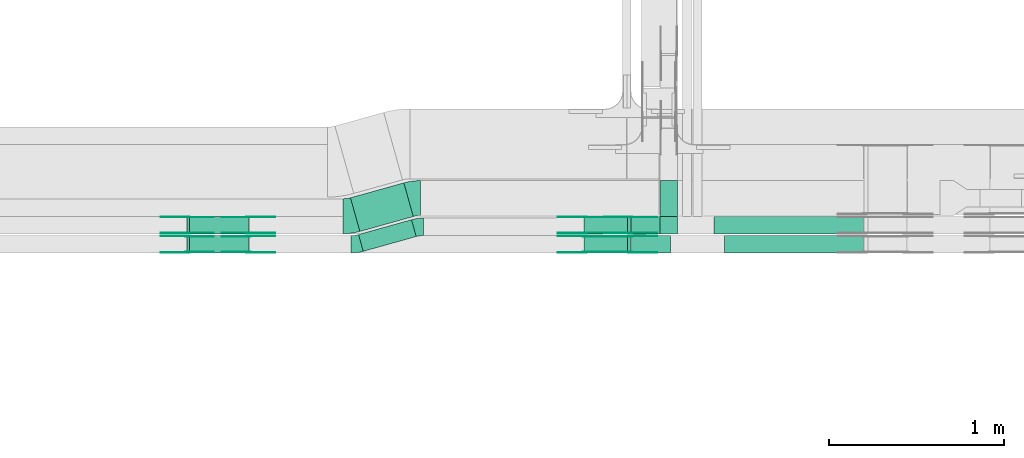
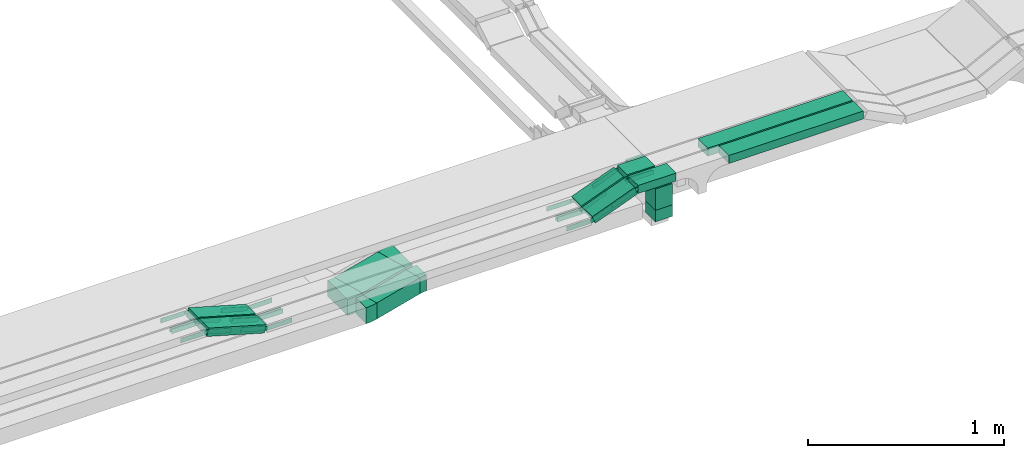
# One storey, part 21 of 27: 37 flow fittings, 11 flow segments.
"""IFC2X3 building model written with IfcOpenShell, lengths in millimetres."""

from ifc_helpers import new_model, entity, si_unit, converted_unit, derived_unit, direction, frame, frame_2d, origin, origin_2d_with_axis, place, context, subcontext, project, spatial, polyline, circle_curve, parameter, trimmed, segment, composite_curve, rectangle, outline, extrude, source, transform, mapped, material, material_list, type_object, type_shapes, element, save


model = new_model("IFC2X3")

# Units and contexts
model_context = context("Model", 3, precision=0.01, world=origin(), true_north=direction((6.12303176911189e-17, 1.0)))
body_context = subcontext(model_context, "Body", "Model", "MODEL_VIEW")
ifc_project = project(units=[si_unit("LENGTHUNIT", "METRE", prefix="MILLI"), si_unit("AREAUNIT", "SQUARE_METRE"), si_unit("VOLUMEUNIT", "CUBIC_METRE"), converted_unit("PLANEANGLEUNIT", "DEGREE", entity("IfcRatioMeasure", 0.0174532925199433), si_unit("PLANEANGLEUNIT", "RADIAN"), dimensions=[0, 0, 0, 0, 0, 0, 0]), si_unit("MASSUNIT", "GRAM", prefix="KILO"), derived_unit("MASSDENSITYUNIT", [(si_unit("MASSUNIT", "GRAM", prefix="KILO"), 1), (si_unit("LENGTHUNIT", "METRE"), -3)]), derived_unit("MOMENTOFINERTIAUNIT", [(si_unit("LENGTHUNIT", "METRE"), 4)]), si_unit("TIMEUNIT", "SECOND"), si_unit("FREQUENCYUNIT", "HERTZ"), si_unit("THERMODYNAMICTEMPERATUREUNIT", "DEGREE_CELSIUS"), derived_unit("THERMALTRANSMITTANCEUNIT", [(si_unit("MASSUNIT", "GRAM", prefix="KILO"), 1), (si_unit("THERMODYNAMICTEMPERATUREUNIT", "KELVIN"), -1), (si_unit("TIMEUNIT", "SECOND"), -3)]), derived_unit("VOLUMETRICFLOWRATEUNIT", [(si_unit("LENGTHUNIT", "METRE"), 3), (si_unit("TIMEUNIT", "SECOND"), -1)]), derived_unit("MASSFLOWRATEUNIT", [(si_unit("MASSUNIT", "GRAM", prefix="KILO"), 1), (si_unit("TIMEUNIT", "SECOND"), -1)]), derived_unit("ROTATIONALFREQUENCYUNIT", [(si_unit("TIMEUNIT", "SECOND"), -1)]), si_unit("ELECTRICCURRENTUNIT", "AMPERE"), si_unit("ELECTRICVOLTAGEUNIT", "VOLT"), si_unit("POWERUNIT", "WATT"), si_unit("FORCEUNIT", "NEWTON", prefix="KILO"), si_unit("ILLUMINANCEUNIT", "LUX"), si_unit("LUMINOUSFLUXUNIT", "LUMEN"), si_unit("LUMINOUSINTENSITYUNIT", "CANDELA"), derived_unit("USERDEFINED", [(si_unit("MASSUNIT", "GRAM", prefix="KILO"), -1), (si_unit("LENGTHUNIT", "METRE"), -2), (si_unit("TIMEUNIT", "SECOND"), 3), (si_unit("LUMINOUSFLUXUNIT", "LUMEN"), 1)]), derived_unit("LINEARVELOCITYUNIT", [(si_unit("LENGTHUNIT", "METRE"), 1), (si_unit("TIMEUNIT", "SECOND"), -1)]), si_unit("PRESSUREUNIT", "PASCAL"), derived_unit("USERDEFINED", [(si_unit("LENGTHUNIT", "METRE"), -2), (si_unit("MASSUNIT", "GRAM", prefix="KILO"), 1), (si_unit("TIMEUNIT", "SECOND"), -2)]), derived_unit("LINEARFORCEUNIT", [(si_unit("MASSUNIT", "GRAM", prefix="KILO"), 1), (si_unit("LENGTHUNIT", "METRE"), 1), (si_unit("TIMEUNIT", "SECOND"), -2), (si_unit("LENGTHUNIT", "METRE"), -1)]), derived_unit("PLANARFORCEUNIT", [(si_unit("MASSUNIT", "GRAM", prefix="KILO"), 1), (si_unit("LENGTHUNIT", "METRE"), 1), (si_unit("TIMEUNIT", "SECOND"), -2), (si_unit("LENGTHUNIT", "METRE"), -2)])], contexts=[model_context])

# Site, building, storey
site_placement = place(None, origin())
site = spatial("IfcSite", under=ifc_project, at=site_placement, CompositionType="ELEMENT")
building_placement = place(site_placement, origin())
building = spatial("IfcBuilding", under=site, at=building_placement, CompositionType="ELEMENT")
storey_placement = place(building_placement, origin())
storey = spatial("IfcBuildingStorey", under=building, at=storey_placement, CompositionType="ELEMENT", Elevation=0.0)

# Flow segments
cable_carrier_segment_type = type_object("IfcCableCarrierSegmentType", PredefinedType="CABLETRAYSEGMENT")
flow_segment_1_placement = place(storey_placement, frame((62283.44, 8309.65, 2600.0)))
element("IfcFlowSegment", 1, at=flow_segment_1_placement, inside=storey, type_object=cable_carrier_segment_type, context=body_context, shape_type="SweptSolid", body=[
    extrude(rectangle(XDim=314.534339130373, YDim=99.9999999999995, at=origin_2d_with_axis()), frame((164.92, 90.44, 0.0), z_axis=(0.0, 0.0, 1.0), x_axis=(0.963181508900073, 0.268851968400788, 0.0)), (0.0, 0.0, 1.0), 100.0),
])
flow_segment_2_placement = place(storey_placement, frame((62237.29, 8423.33, 2600.0)))
element("IfcFlowSegment", 2, at=flow_segment_2_placement, inside=storey, type_object=cable_carrier_segment_type, context=body_context, shape_type="SweptSolid", body=[
    extrude(rectangle(XDim=316.935834936436, YDim=199.999999999999, at=origin_2d_with_axis()), frame((179.52, 138.92, 0.0), z_axis=(0.0, 0.0, 1.0), x_axis=(0.963181508900077, 0.268851968400775, 0.0)), (0.0, 0.0, 1.0), 99.9999999999999),
])
flow_segment_3_placement = place(storey_placement, frame((64007.77, 8409.33, 2550.0)))
element("IfcFlowSegment", 3, at=flow_segment_3_placement, inside=storey, type_object=cable_carrier_segment_type, context=body_context, shape_type="SweptSolid", body=[
    extrude(rectangle(XDim=99.9999999999946, YDim=100.000000000001, at=origin_2d_with_axis()), frame((50.0, 50.0, 0.0), z_axis=(0.0, 0.0, 1.0), x_axis=(-1.0, 0.0, 0.0)), (0.0, 0.0, 1.0), 70.9999999978977),
])
flow_segment_4_placement = place(storey_placement, frame((61302.95, 8410.0, 2752.37)))
element("IfcFlowSegment", 4, at=flow_segment_4_placement, inside=storey, type_object=cable_carrier_segment_type, context=body_context, shape_type="SweptSolid", body=[
    extrude(rectangle(XDim=49.9999999999995, YDim=100.000000000001, at=frame_2d((0.0, 0.0), x_axis=(0.0, 1.0))), frame((6.89, 50.0, 121.23), z_axis=(0.96126169593834, 0.0, -0.275637355816926), x_axis=(0.0, 1.0, 0.0)), (0.0, 0.0, 1.0), 352.64415944179),
])
flow_segment_5_placement = place(storey_placement, frame((61302.95, 8300.0, 2752.37)))
element("IfcFlowSegment", 5, at=flow_segment_5_placement, inside=storey, type_object=cable_carrier_segment_type, context=body_context, shape_type="SweptSolid", body=[
    extrude(rectangle(XDim=49.9999999999984, YDim=99.9999999999989, at=frame_2d((0.0, 0.0), x_axis=(0.0, 1.0))), frame((6.89, 50.0, 121.23), z_axis=(0.961261695938338, 0.0, -0.275637355816932), x_axis=(0.0, 1.0, 0.0)), (0.0, 0.0, 1.0), 352.644159441781),
])
flow_segment_6_placement = place(storey_placement, frame((63843.54, 8410.0, 2850.0)))
element("IfcFlowSegment", 6, at=flow_segment_6_placement, inside=storey, type_object=cable_carrier_segment_type, context=body_context, shape_type="SweptSolid", body=[
    extrude(rectangle(XDim=163.625167697005, YDim=100.000000000001, at=origin_2d_with_axis()), frame((81.81, 50.0, 0.0), z_axis=(0.0, 0.0, 1.0), x_axis=(-1.0, 0.0, 0.0)), (0.0, 0.0, 1.0), 50.0000000000005),
])
flow_segment_7_placement = place(storey_placement, frame((63573.65, 8410.0, 2753.95)))
element("IfcFlowSegment", 7, at=flow_segment_7_placement, inside=storey, type_object=cable_carrier_segment_type, context=body_context, shape_type="SweptSolid", body=[
    extrude(rectangle(XDim=50.0000000000014, YDim=100.000000000001, at=origin_2d_with_axis()), frame((8.96, 50.0, 23.34), z_axis=(0.933580426496962, 0.0, 0.358367949545925), x_axis=(-0.358367949545925, 0.0, 0.933580426496962)), (0.0, 0.0, 1.0), 266.293146356256),
])
flow_segment_8_placement = place(storey_placement, frame((63843.54, 8300.0, 2850.0)))
element("IfcFlowSegment", 8, at=flow_segment_8_placement, inside=storey, type_object=cable_carrier_segment_type, context=body_context, shape_type="SweptSolid", body=[
    extrude(rectangle(XDim=223.777178948546, YDim=99.9999999999989, at=origin_2d_with_axis()), frame((111.89, 50.0, 0.0)), (0.0, 0.0, 1.0), 50.0),
])
flow_segment_9_placement = place(storey_placement, frame((63573.65, 8300.0, 2753.95)))
element("IfcFlowSegment", 9, at=flow_segment_9_placement, inside=storey, type_object=cable_carrier_segment_type, context=body_context, shape_type="SweptSolid", body=[
    extrude(rectangle(XDim=50.0000000000008, YDim=100.000000000001, at=origin_2d_with_axis()), frame((8.96, 50.0, 23.34), z_axis=(0.933580426497027, 0.0, 0.358367949545756), x_axis=(-0.358367949545756, 0.0, 0.933580426497027)), (0.0, 0.0, 1.0), 266.293146356433),
])
flow_segment_10_placement = place(storey_placement, frame((64317.17, 8410.0, 2850.0)))
element("IfcFlowSegment", 10, at=flow_segment_10_placement, inside=storey, type_object=cable_carrier_segment_type, context=body_context, shape_type="SweptSolid", body=[
    extrude(rectangle(XDim=853.173988896064, YDim=100.000000000001, at=origin_2d_with_axis()), frame((426.59, 50.0, 0.0)), (0.0, 0.0, 1.0), 49.9999999999989),
])
flow_segment_11_placement = place(storey_placement, frame((64377.32, 8300.0, 2850.0)))
element("IfcFlowSegment", 11, at=flow_segment_11_placement, inside=storey, type_object=cable_carrier_segment_type, context=body_context, shape_type="SweptSolid", body=[
    extrude(rectangle(XDim=793.021977644722, YDim=100.000000000001, at=origin_2d_with_axis()), frame((396.51, 50.0, 0.0)), (0.0, 0.0, 1.0), 49.9999999999995),
])

# Flow fittings
ifc_material_1 = material(Name="G")
cable_carrier_fitting_type_1 = type_object("IfcCableCarrierFittingType", PredefinedType="NOTDEFINED", material=ifc_material_1)
shared_shape_1 = source(origin(), body_context, "Body", "SweptSolid", [
    extrude(outline(composite_curve([segment(trimmed(circle_curve(frame_2d((-44.59, 0.0), x_axis=(1.0, 0.0)), 12.5), [parameter(90.0000000000007)], [parameter(270.0)], True, "PARAMETER"), True, "CONTINUOUS"), segment(polyline([(-44.59, -12.5), (-33.09, -12.5)]), True, "CONTINUOUS"), segment(polyline([(-33.09, -12.5), (-31.23, -14.5)]), True, "CONTINUOUS"), segment(polyline([(-31.23, -14.5), (108.91, -14.5)]), True, "CONTINUOUS"), segment(polyline([(108.91, -14.5), (108.91, 14.5)]), True, "CONTINUOUS"), segment(polyline([(108.91, 14.5), (-31.23, 14.5)]), True, "CONTINUOUS"), segment(polyline([(-31.23, 14.5), (-33.09, 12.5)]), True, "CONTINUOUS"), segment(polyline([(-33.09, 12.5), (-44.59, 12.5)]), True, "CONTINUOUS")], self_intersect=False)), frame((44.59, 0.0, 0.0), z_axis=(0.0, 0.0, -1.0), x_axis=(1.0, 0.0, 0.0)), (0.0, 0.0, -1.0), 2.0),
])
type_shapes(cable_carrier_fitting_type_1, [shared_shape_1])
flow_fitting_1_placement = place(storey_placement, frame((63837.17, 8414.54, 2875.0), z_axis=(0.0, -1.0, 0.0), x_axis=(-0.933580426497204, 0.0, -0.358367949545295)))
element("IfcFlowFitting", 12, at=flow_fitting_1_placement, inside=storey, type_object=cable_carrier_fitting_type_1, material=ifc_material_1, context=body_context, shape_type="MappedRepresentation", body=[
    mapped(shared_shape_1, transform((0.0, 0.0, 0.0), scale=1.0)),
])
cable_carrier_fitting_type_2 = type_object("IfcCableCarrierFittingType", PredefinedType="NOTDEFINED", material=ifc_material_1)
type_shapes(cable_carrier_fitting_type_2, [shared_shape_1])
flow_fitting_2_placement = place(storey_placement, frame((63837.17, 8503.46, 2875.0), z_axis=(0.0, 1.0, 0.0), x_axis=(1.0, 0.0, 0.0)))
element("IfcFlowFitting", 13, at=flow_fitting_2_placement, inside=storey, type_object=cable_carrier_fitting_type_2, material=ifc_material_1, context=body_context, shape_type="MappedRepresentation", body=[
    mapped(shared_shape_1, transform((0.0, 0.0, 0.0), scale=1.0)),
])
flow_fitting_3_placement = place(storey_placement, frame((61653.7, 8414.54, 2775.0), z_axis=(0.0, -1.0, 0.0), x_axis=(1.0, 0.0, 0.0)))
element("IfcFlowFitting", 14, at=flow_fitting_3_placement, inside=storey, type_object=cable_carrier_fitting_type_1, material=ifc_material_1, context=body_context, shape_type="MappedRepresentation", body=[
    mapped(shared_shape_1, transform((0.0, 0.0, 0.0), scale=1.0)),
])
flow_fitting_4_placement = place(storey_placement, frame((61653.7, 8503.46, 2775.0), z_axis=(0.0, 1.0, 0.0), x_axis=(-0.961261695938351, 0.0, 0.275637355816886)))
element("IfcFlowFitting", 15, at=flow_fitting_4_placement, inside=storey, type_object=cable_carrier_fitting_type_2, material=ifc_material_1, context=body_context, shape_type="MappedRepresentation", body=[
    mapped(shared_shape_1, transform((0.0, 0.0, 0.0), scale=1.0)),
])
flow_fitting_5_placement = place(storey_placement, frame((63576.66, 8505.46, 2775.0), z_axis=(0.0, 1.0, 0.0), x_axis=(-1.0, 0.0, 0.0)))
element("IfcFlowFitting", 16, at=flow_fitting_5_placement, inside=storey, type_object=cable_carrier_fitting_type_1, material=ifc_material_1, context=body_context, shape_type="MappedRepresentation", body=[
    mapped(shared_shape_1, transform((0.0, 0.0, 0.0), scale=1.0)),
])
flow_fitting_6_placement = place(storey_placement, frame((63576.66, 8416.54, 2775.0), z_axis=(0.0, -1.0, 0.0), x_axis=(0.93358042649699, 0.0, 0.358367949545852)))
element("IfcFlowFitting", 17, at=flow_fitting_6_placement, inside=storey, type_object=cable_carrier_fitting_type_2, material=ifc_material_1, context=body_context, shape_type="MappedRepresentation", body=[
    mapped(shared_shape_1, transform((0.0, 0.0, 0.0), scale=1.0)),
])
flow_fitting_7_placement = place(storey_placement, frame((61653.7, 8304.54, 2775.0), z_axis=(0.0, -1.0, 0.0), x_axis=(1.0, 0.0, 0.0)))
element("IfcFlowFitting", 18, at=flow_fitting_7_placement, inside=storey, type_object=cable_carrier_fitting_type_1, material=ifc_material_1, context=body_context, shape_type="MappedRepresentation", body=[
    mapped(shared_shape_1, transform((0.0, 0.0, 0.0), scale=1.0)),
])
flow_fitting_8_placement = place(storey_placement, frame((61653.7, 8393.46, 2775.0), z_axis=(0.0, 1.0, 0.0), x_axis=(-0.961261695938352, 0.0, 0.275637355816883)))
element("IfcFlowFitting", 19, at=flow_fitting_8_placement, inside=storey, type_object=cable_carrier_fitting_type_2, material=ifc_material_1, context=body_context, shape_type="MappedRepresentation", body=[
    mapped(shared_shape_1, transform((0.0, 0.0, 0.0), scale=1.0)),
])
flow_fitting_9_placement = place(storey_placement, frame((63576.66, 8395.46, 2775.0), z_axis=(0.0, 1.0, 0.0), x_axis=(-1.0, 0.0, 0.0)))
element("IfcFlowFitting", 20, at=flow_fitting_9_placement, inside=storey, type_object=cable_carrier_fitting_type_1, material=ifc_material_1, context=body_context, shape_type="MappedRepresentation", body=[
    mapped(shared_shape_1, transform((0.0, 0.0, 0.0), scale=1.0)),
])
flow_fitting_10_placement = place(storey_placement, frame((63576.66, 8306.54, 2775.0), z_axis=(0.0, -1.0, 0.0), x_axis=(0.933580426497054, 0.0, 0.358367949545685)))
element("IfcFlowFitting", 21, at=flow_fitting_10_placement, inside=storey, type_object=cable_carrier_fitting_type_2, material=ifc_material_1, context=body_context, shape_type="MappedRepresentation", body=[
    mapped(shared_shape_1, transform((0.0, 0.0, 0.0), scale=1.0)),
])
flow_fitting_11_placement = place(storey_placement, frame((63837.17, 8395.46, 2875.0), z_axis=(0.0, 1.0, 0.0), x_axis=(1.0, 0.0, 0.0)))
element("IfcFlowFitting", 22, at=flow_fitting_11_placement, inside=storey, type_object=cable_carrier_fitting_type_1, material=ifc_material_1, context=body_context, shape_type="MappedRepresentation", body=[
    mapped(shared_shape_1, transform((0.0, 0.0, 0.0), scale=1.0)),
])
flow_fitting_12_placement = place(storey_placement, frame((63837.17, 8306.54, 2875.0), z_axis=(0.0, -1.0, 0.0), x_axis=(-0.933580426497046, 0.0, -0.358367949545707)))
element("IfcFlowFitting", 23, at=flow_fitting_12_placement, inside=storey, type_object=cable_carrier_fitting_type_2, material=ifc_material_1, context=body_context, shape_type="MappedRepresentation", body=[
    mapped(shared_shape_1, transform((0.0, 0.0, 0.0), scale=1.0)),
])
flow_fitting_13_placement = place(storey_placement, frame((61304.96, 8414.54, 2875.0), z_axis=(0.0, -1.0, 0.0), x_axis=(-1.0, 0.0, 0.0)))
element("IfcFlowFitting", 24, at=flow_fitting_13_placement, inside=storey, type_object=cable_carrier_fitting_type_1, material=ifc_material_1, context=body_context, shape_type="MappedRepresentation", body=[
    mapped(shared_shape_1, transform((0.0, 0.0, 0.0), scale=1.0)),
])
flow_fitting_14_placement = place(storey_placement, frame((61304.96, 8503.46, 2875.0), z_axis=(0.0, 1.0, 0.0), x_axis=(0.961261695938351, 0.0, -0.275637355816886)))
element("IfcFlowFitting", 25, at=flow_fitting_14_placement, inside=storey, type_object=cable_carrier_fitting_type_2, material=ifc_material_1, context=body_context, shape_type="MappedRepresentation", body=[
    mapped(shared_shape_1, transform((0.0, 0.0, 0.0), scale=1.0)),
])
flow_fitting_15_placement = place(storey_placement, frame((61304.96, 8304.54, 2875.0), z_axis=(0.0, -1.0, 0.0), x_axis=(-1.0, 0.0, 0.0)))
element("IfcFlowFitting", 26, at=flow_fitting_15_placement, inside=storey, type_object=cable_carrier_fitting_type_1, material=ifc_material_1, context=body_context, shape_type="MappedRepresentation", body=[
    mapped(shared_shape_1, transform((0.0, 0.0, 0.0), scale=1.0)),
])
flow_fitting_16_placement = place(storey_placement, frame((61304.96, 8393.46, 2875.0), z_axis=(0.0, 1.0, 0.0), x_axis=(0.961261695938352, 0.0, -0.275637355816883)))
element("IfcFlowFitting", 27, at=flow_fitting_16_placement, inside=storey, type_object=cable_carrier_fitting_type_2, material=ifc_material_1, context=body_context, shape_type="MappedRepresentation", body=[
    mapped(shared_shape_1, transform((0.0, 0.0, 0.0), scale=1.0)),
])
cable_carrier_fitting_type_3 = type_object("IfcCableCarrierFittingType", PredefinedType="NOTDEFINED", material=ifc_material_1)
shared_shape_2 = source(origin(), body_context, "Body", "SweptSolid", [
    extrude(outline(composite_curve([segment(trimmed(circle_curve(frame_2d((-44.59, 0.0), x_axis=(1.0, 0.0)), 12.5), [parameter(90.0000000000007)], [parameter(270.0)], True, "PARAMETER"), True, "CONTINUOUS"), segment(polyline([(-44.59, -12.5), (-33.09, -12.5)]), True, "CONTINUOUS"), segment(polyline([(-33.09, -12.5), (-31.23, -14.5)]), True, "CONTINUOUS"), segment(polyline([(-31.23, -14.5), (108.91, -14.5)]), True, "CONTINUOUS"), segment(polyline([(108.91, -14.5), (108.91, 14.5)]), True, "CONTINUOUS"), segment(polyline([(108.91, 14.5), (-31.23, 14.5)]), True, "CONTINUOUS"), segment(polyline([(-31.23, 14.5), (-33.09, 12.5)]), True, "CONTINUOUS"), segment(polyline([(-33.09, 12.5), (-44.59, 12.5)]), True, "CONTINUOUS")], self_intersect=False)), frame((44.59, 0.0, 0.0)), (0.0, 0.0, 1.0), 2.0),
])
type_shapes(cable_carrier_fitting_type_3, [shared_shape_2])
flow_fitting_17_placement = place(storey_placement, frame((63837.17, 8505.46, 2875.0), z_axis=(0.0, 1.0, 0.0), x_axis=(-0.933580426497204, 0.0, -0.358367949545295)))
element("IfcFlowFitting", 28, at=flow_fitting_17_placement, inside=storey, type_object=cable_carrier_fitting_type_3, material=ifc_material_1, context=body_context, shape_type="MappedRepresentation", body=[
    mapped(shared_shape_2, transform((0.0, 0.0, 0.0), scale=1.0)),
])
cable_carrier_fitting_type_4 = type_object("IfcCableCarrierFittingType", PredefinedType="NOTDEFINED", material=ifc_material_1)
type_shapes(cable_carrier_fitting_type_4, [shared_shape_2])
flow_fitting_18_placement = place(storey_placement, frame((63837.17, 8416.54, 2875.0), z_axis=(0.0, -1.0, 0.0), x_axis=(1.0, 0.0, 0.0)))
element("IfcFlowFitting", 29, at=flow_fitting_18_placement, inside=storey, type_object=cable_carrier_fitting_type_4, material=ifc_material_1, context=body_context, shape_type="MappedRepresentation", body=[
    mapped(shared_shape_2, transform((0.0, 0.0, 0.0), scale=1.0)),
])
flow_fitting_19_placement = place(storey_placement, frame((61653.7, 8505.46, 2775.0), z_axis=(0.0, 1.0, 0.0), x_axis=(1.0, 0.0, 0.0)))
element("IfcFlowFitting", 30, at=flow_fitting_19_placement, inside=storey, type_object=cable_carrier_fitting_type_3, material=ifc_material_1, context=body_context, shape_type="MappedRepresentation", body=[
    mapped(shared_shape_2, transform((0.0, 0.0, 0.0), scale=1.0)),
])
flow_fitting_20_placement = place(storey_placement, frame((61653.7, 8416.54, 2775.0), z_axis=(0.0, -1.0, 0.0), x_axis=(-0.961261695938351, 0.0, 0.275637355816886)))
element("IfcFlowFitting", 31, at=flow_fitting_20_placement, inside=storey, type_object=cable_carrier_fitting_type_4, material=ifc_material_1, context=body_context, shape_type="MappedRepresentation", body=[
    mapped(shared_shape_2, transform((0.0, 0.0, 0.0), scale=1.0)),
])
flow_fitting_21_placement = place(storey_placement, frame((63576.66, 8414.54, 2775.0), z_axis=(0.0, -1.0, 0.0), x_axis=(-1.0, 0.0, 0.0)))
element("IfcFlowFitting", 32, at=flow_fitting_21_placement, inside=storey, type_object=cable_carrier_fitting_type_3, material=ifc_material_1, context=body_context, shape_type="MappedRepresentation", body=[
    mapped(shared_shape_2, transform((0.0, 0.0, 0.0), scale=1.0)),
])
flow_fitting_22_placement = place(storey_placement, frame((63576.66, 8503.46, 2775.0), z_axis=(0.0, 1.0, 0.0), x_axis=(0.93358042649699, 0.0, 0.358367949545852)))
element("IfcFlowFitting", 33, at=flow_fitting_22_placement, inside=storey, type_object=cable_carrier_fitting_type_4, material=ifc_material_1, context=body_context, shape_type="MappedRepresentation", body=[
    mapped(shared_shape_2, transform((0.0, 0.0, 0.0), scale=1.0)),
])
flow_fitting_23_placement = place(storey_placement, frame((61653.7, 8395.46, 2775.0), z_axis=(0.0, 1.0, 0.0), x_axis=(1.0, 0.0, 0.0)))
element("IfcFlowFitting", 34, at=flow_fitting_23_placement, inside=storey, type_object=cable_carrier_fitting_type_3, material=ifc_material_1, context=body_context, shape_type="MappedRepresentation", body=[
    mapped(shared_shape_2, transform((0.0, 0.0, 0.0), scale=1.0)),
])
flow_fitting_24_placement = place(storey_placement, frame((61653.7, 8306.54, 2775.0), z_axis=(0.0, -1.0, 0.0), x_axis=(-0.961261695938352, 0.0, 0.275637355816883)))
element("IfcFlowFitting", 35, at=flow_fitting_24_placement, inside=storey, type_object=cable_carrier_fitting_type_4, material=ifc_material_1, context=body_context, shape_type="MappedRepresentation", body=[
    mapped(shared_shape_2, transform((0.0, 0.0, 0.0), scale=1.0)),
])
flow_fitting_25_placement = place(storey_placement, frame((63576.66, 8304.54, 2775.0), z_axis=(0.0, -1.0, 0.0), x_axis=(-1.0, 0.0, 0.0)))
element("IfcFlowFitting", 36, at=flow_fitting_25_placement, inside=storey, type_object=cable_carrier_fitting_type_3, material=ifc_material_1, context=body_context, shape_type="MappedRepresentation", body=[
    mapped(shared_shape_2, transform((0.0, 0.0, 0.0), scale=1.0)),
])
flow_fitting_26_placement = place(storey_placement, frame((63576.66, 8393.46, 2775.0), z_axis=(0.0, 1.0, 0.0), x_axis=(0.933580426497054, 0.0, 0.358367949545685)))
element("IfcFlowFitting", 37, at=flow_fitting_26_placement, inside=storey, type_object=cable_carrier_fitting_type_4, material=ifc_material_1, context=body_context, shape_type="MappedRepresentation", body=[
    mapped(shared_shape_2, transform((0.0, 0.0, 0.0), scale=1.0)),
])
flow_fitting_27_placement = place(storey_placement, frame((63837.17, 8304.54, 2875.0), z_axis=(0.0, -1.0, 0.0), x_axis=(1.0, 0.0, 0.0)))
element("IfcFlowFitting", 38, at=flow_fitting_27_placement, inside=storey, type_object=cable_carrier_fitting_type_3, material=ifc_material_1, context=body_context, shape_type="MappedRepresentation", body=[
    mapped(shared_shape_2, transform((0.0, 0.0, 0.0), scale=1.0)),
])
flow_fitting_28_placement = place(storey_placement, frame((63837.17, 8393.46, 2875.0), z_axis=(0.0, 1.0, 0.0), x_axis=(-0.933580426497046, 0.0, -0.358367949545707)))
element("IfcFlowFitting", 39, at=flow_fitting_28_placement, inside=storey, type_object=cable_carrier_fitting_type_4, material=ifc_material_1, context=body_context, shape_type="MappedRepresentation", body=[
    mapped(shared_shape_2, transform((0.0, 0.0, 0.0), scale=1.0)),
])
flow_fitting_29_placement = place(storey_placement, frame((61304.96, 8505.46, 2875.0), z_axis=(0.0, 1.0, 0.0), x_axis=(-1.0, 0.0, 0.0)))
element("IfcFlowFitting", 40, at=flow_fitting_29_placement, inside=storey, type_object=cable_carrier_fitting_type_3, material=ifc_material_1, context=body_context, shape_type="MappedRepresentation", body=[
    mapped(shared_shape_2, transform((0.0, 0.0, 0.0), scale=1.0)),
])
flow_fitting_30_placement = place(storey_placement, frame((61304.96, 8416.54, 2875.0), z_axis=(0.0, -1.0, 0.0), x_axis=(0.961261695938351, 0.0, -0.275637355816886)))
element("IfcFlowFitting", 41, at=flow_fitting_30_placement, inside=storey, type_object=cable_carrier_fitting_type_4, material=ifc_material_1, context=body_context, shape_type="MappedRepresentation", body=[
    mapped(shared_shape_2, transform((0.0, 0.0, 0.0), scale=1.0)),
])
flow_fitting_31_placement = place(storey_placement, frame((61304.96, 8395.46, 2875.0), z_axis=(0.0, 1.0, 0.0), x_axis=(-1.0, 0.0, 0.0)))
element("IfcFlowFitting", 42, at=flow_fitting_31_placement, inside=storey, type_object=cable_carrier_fitting_type_3, material=ifc_material_1, context=body_context, shape_type="MappedRepresentation", body=[
    mapped(shared_shape_2, transform((0.0, 0.0, 0.0), scale=1.0)),
])
flow_fitting_32_placement = place(storey_placement, frame((61304.96, 8306.54, 2875.0), z_axis=(0.0, -1.0, 0.0), x_axis=(0.961261695938352, 0.0, -0.275637355816883)))
element("IfcFlowFitting", 43, at=flow_fitting_32_placement, inside=storey, type_object=cable_carrier_fitting_type_4, material=ifc_material_1, context=body_context, shape_type="MappedRepresentation", body=[
    mapped(shared_shape_2, transform((0.0, 0.0, 0.0), scale=1.0)),
])
ifc_material_2 = material()
cable_carrier_fitting_type_5 = type_object("IfcCableCarrierFittingType", Name="470_DKC_S5_Variable Angle Elbow 0-45:-", PredefinedType="NOTDEFINED", material=ifc_material_2)
shared_shape_3 = source(origin(), body_context, "Body", "SweptSolid", [
    extrude(outline(composite_curve([segment(polyline([(-27.88, -53.75), (-26.88, -53.75)]), True, "CONTINUOUS"), segment(trimmed(circle_curve(frame_2d((-26.88, 196.25), x_axis=(0.0, -1.0)), 250.0), [parameter(0.0)], [parameter(15.5959637059961)], True, "PARAMETER"), True, "CONTINUOUS"), segment(polyline([(40.34, -44.54), (41.3, -44.28)]), True, "CONTINUOUS"), segment(polyline([(41.3, -44.28), (14.41, 52.04)]), True, "CONTINUOUS"), segment(polyline([(14.41, 52.04), (13.45, 51.77)]), True, "CONTINUOUS"), segment(trimmed(circle_curve(frame_2d((-26.88, 196.25), x_axis=(0.0, -1.0)), 150.0), [parameter(0.0)], [parameter(15.5959637059961)], True, "PARAMETER"), False, "CONTINUOUS"), segment(polyline([(-26.88, 46.25), (-27.88, 46.25)]), True, "CONTINUOUS"), segment(polyline([(-27.88, 46.25), (-27.88, -53.75)]), True, "CONTINUOUS")], self_intersect=False)), frame((-0.51, 3.75, -50.0)), (0.0, 0.0, 1.0), 100.0),
])
type_shapes(cable_carrier_fitting_type_5, [shared_shape_3])
flow_fitting_33_placement = place(storey_placement, frame((62627.18, 8450.0, 2650.0), z_axis=(0.0, 0.0, 1.0), x_axis=(-1.0, 0.0, 0.0)))
element("IfcFlowFitting", 44, at=flow_fitting_33_placement, inside=storey, type_object=cable_carrier_fitting_type_5, material=ifc_material_2, Name="470_DKC_S5_Variable Angle Elbow 0-45:-", ObjectType="470_DKC_S5_Variable Angle Elbow 0-45:-", context=body_context, shape_type="MappedRepresentation", body=[
    mapped(shared_shape_3, transform((0.0, 0.0, 0.0), scale=1.0)),
])
flow_fitting_34_placement = place(storey_placement, frame((62269.54, 8350.17, 2650.0)))
element("IfcFlowFitting", 45, at=flow_fitting_34_placement, inside=storey, type_object=cable_carrier_fitting_type_5, material=ifc_material_2, Name="470_DKC_S5_Variable Angle Elbow 0-45:-", ObjectType="470_DKC_S5_Variable Angle Elbow 0-45:-", context=body_context, shape_type="MappedRepresentation", body=[
    mapped(shared_shape_3, transform((0.0, 0.0, 0.0), scale=1.0)),
])
ifc_material_list = material_list([ifc_material_2, ifc_material_2, ifc_material_2, ifc_material_2, ifc_material_2])
cable_carrier_fitting_type_6 = type_object("IfcCableCarrierFittingType", PredefinedType="NOTDEFINED", material=ifc_material_list)
shared_shape_4 = source(origin(), body_context, "Body", "SweptSolid", [
    extrude(outline(composite_curve([segment(polyline([(-61.86, -174.29), (-7.86, -174.29)]), True, "CONTINUOUS"), segment(polyline([(-7.86, -174.29), (-7.86, 25.71)]), True, "CONTINUOUS"), segment(trimmed(circle_curve(frame_2d((-2.86, 25.71), x_axis=(0.0, -1.0)), 5.0), [parameter(180.0)], [parameter(270.0)], True, "PARAMETER"), False, "CONTINUOUS"), segment(polyline([(-2.86, 30.71), (71.14, 30.71)]), True, "CONTINUOUS"), segment(polyline([(71.14, 30.71), (71.14, 130.71)]), True, "CONTINUOUS"), segment(polyline([(71.14, 130.71), (-61.86, 130.71)]), True, "CONTINUOUS"), segment(polyline([(-61.86, 130.71), (-61.86, -174.29)]), True, "CONTINUOUS")], self_intersect=False)), frame((-74.29, -50.0, 42.14), z_axis=(0.0, 1.0, 0.0), x_axis=(0.0, 0.0, -1.0)), (0.0, 0.0, 1.0), 0.800000000000055),
    extrude(rectangle(XDim=0.799999999999954, YDim=100.0, at=origin_2d_with_axis()), frame((99.6, 0.0, 17.5), z_axis=(0.0, 0.0, 1.0), x_axis=(-1.0, 0.0, 0.0)), (0.0, 0.0, 1.0), 86.4999999999732),
    extrude(rectangle(XDim=305.0, YDim=100.0, at=origin_2d_with_axis()), frame((-52.5, 0.0, 103.2), z_axis=(0.0, 0.0, 1.0), x_axis=(-1.0, 0.0, 0.0)), (0.0, 0.0, 1.0), 0.800000000000106),
    extrude(rectangle(XDim=0.799999999999852, YDim=98.4000000000001, at=origin_2d_with_axis()), frame((-204.6, 0.0, -29.0), z_axis=(0.0, 0.0, 1.0), x_axis=(-1.0, 0.0, 0.0)), (0.0, 0.0, 1.0), 133.0),
    extrude(outline(composite_curve([segment(polyline([(-61.86, -174.29), (-7.86, -174.29)]), True, "CONTINUOUS"), segment(polyline([(-7.86, -174.29), (-7.86, 25.71)]), True, "CONTINUOUS"), segment(trimmed(circle_curve(frame_2d((-2.86, 25.71), x_axis=(0.0, -1.0)), 5.0), [parameter(180.0)], [parameter(270.0)], True, "PARAMETER"), False, "CONTINUOUS"), segment(polyline([(-2.86, 30.71), (71.14, 30.71)]), True, "CONTINUOUS"), segment(polyline([(71.14, 30.71), (71.14, 130.71)]), True, "CONTINUOUS"), segment(polyline([(71.14, 130.71), (-61.86, 130.71)]), True, "CONTINUOUS"), segment(polyline([(-61.86, 130.71), (-61.86, -174.29)]), True, "CONTINUOUS")], self_intersect=False)), frame((-74.29, 49.2, 42.14), z_axis=(0.0, 1.0, 0.0), x_axis=(0.0, 0.0, -1.0)), (0.0, 0.0, 1.0), 0.799999999999835),
])
type_shapes(cable_carrier_fitting_type_6, [shared_shape_4])
flow_fitting_35_placement = place(storey_placement, frame((64057.77, 8614.33, 2650.0), z_axis=(0.0, 0.0, 1.0), x_axis=(0.0, 1.0, 0.0)))
element("IfcFlowFitting", 46, at=flow_fitting_35_placement, inside=storey, type_object=cable_carrier_fitting_type_6, material=ifc_material_list, Name="470_DKC_S5_vertical T-shaped cover", context=body_context, shape_type="MappedRepresentation", body=[
    mapped(shared_shape_4, transform((0.0, 0.0, 0.0), scale=1.0)),
])
cable_carrier_fitting_type_7 = type_object("IfcCableCarrierFittingType", Name="470_DKC_S5_Variable Angle Elbow 0-45:-", PredefinedType="NOTDEFINED", material=ifc_material_2)
shared_shape_5 = source(origin(), body_context, "Body", "SweptSolid", [
    extrude(outline(composite_curve([segment(polyline([(-34.6, -104.67), (-33.6, -104.67)]), True, "CONTINUOUS"), segment(trimmed(circle_curve(frame_2d((-33.6, 245.33), x_axis=(0.0, -1.0)), 350.0), [parameter(0.0)], [parameter(15.5959637059979)], True, "PARAMETER"), True, "CONTINUOUS"), segment(polyline([(60.5, -91.78), (61.46, -91.51)]), True, "CONTINUOUS"), segment(polyline([(61.46, -91.51), (7.69, 101.12)]), True, "CONTINUOUS"), segment(polyline([(7.69, 101.12), (6.73, 100.85)]), True, "CONTINUOUS"), segment(trimmed(circle_curve(frame_2d((-33.6, 245.33), x_axis=(0.0, -1.0)), 150.0), [parameter(0.0)], [parameter(15.5959637059979)], True, "PARAMETER"), False, "CONTINUOUS"), segment(polyline([(-33.6, 95.33), (-34.6, 95.33)]), True, "CONTINUOUS"), segment(polyline([(-34.6, 95.33), (-34.6, -104.67)]), True, "CONTINUOUS")], self_intersect=False)), frame((-0.64, 4.67, -50.0)), (0.0, 0.0, 1.0), 100.0),
])
type_shapes(cable_carrier_fitting_type_7, [shared_shape_5])
flow_fitting_36_placement = place(storey_placement, frame((62603.39, 8614.33, 2650.0), z_axis=(0.0, 0.0, 1.0), x_axis=(-1.0, 0.0, 0.0)))
element("IfcFlowFitting", 47, at=flow_fitting_36_placement, inside=storey, type_object=cable_carrier_fitting_type_7, material=ifc_material_2, Name="470_DKC_S5_Variable Angle Elbow 0-45:-", ObjectType="470_DKC_S5_Variable Angle Elbow 0-45:-", context=body_context, shape_type="MappedRepresentation", body=[
    mapped(shared_shape_5, transform((0.0, 0.0, 0.0), scale=1.0)),
])
flow_fitting_37_placement = place(storey_placement, frame((62230.24, 8510.17, 2650.0)))
element("IfcFlowFitting", 48, at=flow_fitting_37_placement, inside=storey, type_object=cable_carrier_fitting_type_7, material=ifc_material_2, Name="470_DKC_S5_Variable Angle Elbow 0-45:-", ObjectType="470_DKC_S5_Variable Angle Elbow 0-45:-", context=body_context, shape_type="MappedRepresentation", body=[
    mapped(shared_shape_5, transform((0.0, 0.0, 0.0), scale=1.0)),
])

save(model, "model.ifc")
